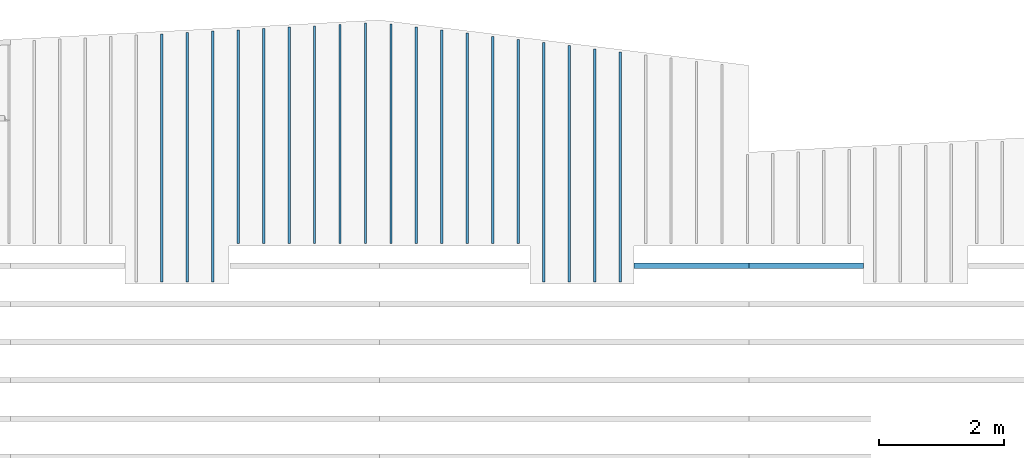
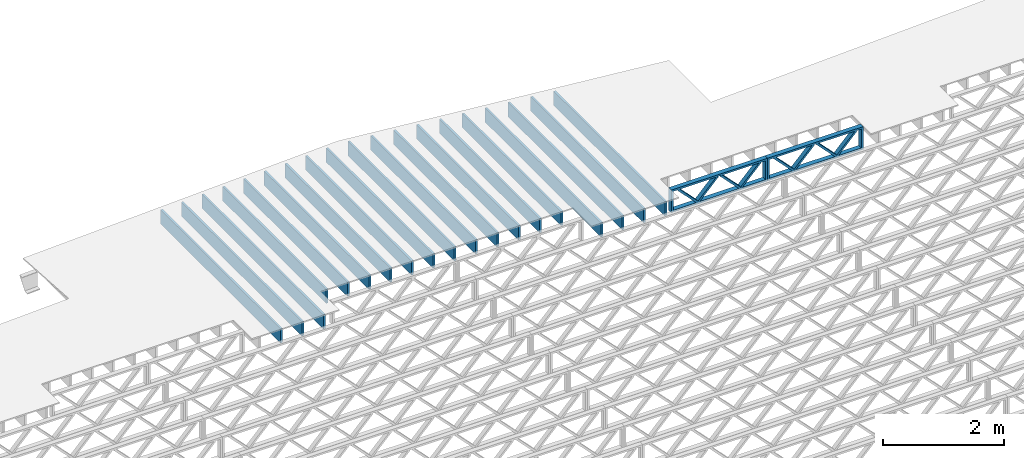
# One storey, part 8 of 12: 21 beams, 3 elements without a shape of their own.
"""IFC4 building model written with IfcOpenShell, lengths in feet."""

from ifc_helpers import new_model, entity, si_unit, converted_unit, derived_unit, direction, frame, frame_2d, origin, origin_2d_with_axis, place, context, subcontext, project, spatial, rectangle, extrude, source, transform, mapped, material, material_profile, profile_set, profile_usage, type_object, type_shapes, element, aggregate, save


model = new_model("IFC4")

# Units and contexts
model_context = context("Model", 3, precision=0.0001, world=origin(), true_north=direction((6.12303176911189e-17, 1.0)))
body_context = subcontext(model_context, "Body", "Model", "MODEL_VIEW")
ifc_project = project(units=[converted_unit("LENGTHUNIT", "FOOT", entity("IfcRatioMeasure", 0.3048), si_unit("LENGTHUNIT", "METRE"), dimensions=[1, 0, 0, 0, 0, 0, 0]), converted_unit("AREAUNIT", "SQUARE FOOT", entity("IfcRatioMeasure", 0.09290304), si_unit("AREAUNIT", "SQUARE_METRE"), dimensions=[2, 0, 0, 0, 0, 0, 0]), converted_unit("VOLUMEUNIT", "CUBIC FOOT", entity("IfcRatioMeasure", 0.028316846592), si_unit("VOLUMEUNIT", "CUBIC_METRE"), dimensions=[3, 0, 0, 0, 0, 0, 0]), converted_unit("PLANEANGLEUNIT", "DEGREE", entity("IfcRatioMeasure", 0.0174532925199433), si_unit("PLANEANGLEUNIT", "RADIAN"), dimensions=[0, 0, 0, 0, 0, 0, 0]), si_unit("MASSUNIT", "GRAM", prefix="KILO"), derived_unit("MASSDENSITYUNIT", [(si_unit("MASSUNIT", "GRAM", prefix="KILO"), 1), (si_unit("LENGTHUNIT", "METRE"), -3)]), derived_unit("MOMENTOFINERTIAUNIT", [(si_unit("LENGTHUNIT", "METRE"), 4)]), si_unit("TIMEUNIT", "SECOND"), si_unit("FREQUENCYUNIT", "HERTZ"), si_unit("THERMODYNAMICTEMPERATUREUNIT", "DEGREE_CELSIUS"), derived_unit("THERMALTRANSMITTANCEUNIT", [(si_unit("MASSUNIT", "GRAM", prefix="KILO"), 1), (si_unit("THERMODYNAMICTEMPERATUREUNIT", "KELVIN"), -1), (si_unit("TIMEUNIT", "SECOND"), -3)]), derived_unit("VOLUMETRICFLOWRATEUNIT", [(si_unit("LENGTHUNIT", "METRE"), 3), (si_unit("TIMEUNIT", "SECOND"), -1)]), si_unit("ELECTRICCURRENTUNIT", "AMPERE"), si_unit("ELECTRICVOLTAGEUNIT", "VOLT"), si_unit("POWERUNIT", "WATT"), si_unit("FORCEUNIT", "NEWTON"), si_unit("ILLUMINANCEUNIT", "LUX"), si_unit("LUMINOUSFLUXUNIT", "LUMEN"), si_unit("LUMINOUSINTENSITYUNIT", "CANDELA"), derived_unit("USERDEFINED", [(si_unit("MASSUNIT", "GRAM", prefix="KILO"), -1), (si_unit("LENGTHUNIT", "METRE"), -2), (si_unit("TIMEUNIT", "SECOND"), 3), (si_unit("LUMINOUSFLUXUNIT", "LUMEN"), 1)]), derived_unit("LINEARVELOCITYUNIT", [(si_unit("LENGTHUNIT", "METRE"), 1), (si_unit("TIMEUNIT", "SECOND"), -1)]), si_unit("PRESSUREUNIT", "PASCAL"), derived_unit("USERDEFINED", [(si_unit("LENGTHUNIT", "METRE"), -2), (si_unit("MASSUNIT", "GRAM", prefix="KILO"), 1), (si_unit("TIMEUNIT", "SECOND"), -2)]), derived_unit("LINEARFORCEUNIT", [(si_unit("MASSUNIT", "GRAM", prefix="KILO"), 1), (si_unit("LENGTHUNIT", "METRE"), 1), (si_unit("TIMEUNIT", "SECOND"), -2), (si_unit("LENGTHUNIT", "METRE"), -1)]), derived_unit("PLANARFORCEUNIT", [(si_unit("MASSUNIT", "GRAM", prefix="KILO"), 1), (si_unit("LENGTHUNIT", "METRE"), 1), (si_unit("TIMEUNIT", "SECOND"), -2), (si_unit("LENGTHUNIT", "METRE"), -2)])], contexts=[model_context])

# Site, building, storey
site_placement = place(None, origin())
site = spatial("IfcSite", under=ifc_project, at=site_placement, CompositionType="ELEMENT")
building_placement = place(site_placement, origin())
building = spatial("IfcBuilding", under=site, at=building_placement, CompositionType="ELEMENT")
storey_placement = place(building_placement, frame((0.0, 0.0, 21.46875)))
storey = spatial("IfcBuildingStorey", under=building, at=storey_placement, Name="3RD FLOOR", CompositionType="ELEMENT", Elevation=21.46875)

# Assembly, beam
assembly_1_placement = place(storey_placement, origin())
assembly_1 = element("IfcElementAssembly", 1, at=assembly_1_placement, inside=storey, Name="Structural Beam System:Structural Framing System", ObjectType="Structural Beam System:Structural Framing System", AssemblyPlace="NOTDEFINED", PredefinedType="BEAM_GRID")
ifc_material_1 = material(Name="WOOD TRUSS", Category="Materials")
ifc_material_profile_1 = material_profile(ifc_material_1, rectangle(XDim=1.73473973950632, YDim=0.125, at=frame_2d((-1.11022302462516e-16, 8.32667268468867e-17), x_axis=(1.0, 0.0))))
ifc_material_profile_2 = material_profile(ifc_material_1, rectangle(XDim=1.73473973950633, YDim=0.125, at=frame_2d((-1.11022302462516e-16, 8.32667268468867e-17), x_axis=(1.0, 0.0))))
ifc_material_profile_3 = material_profile(ifc_material_1, rectangle(XDim=1.73473973950632, YDim=0.125, at=frame_2d((-5.55111512312578e-17, 1.38777878078145e-16), x_axis=(1.0, 0.0))))
ifc_material_profile_4 = material_profile(ifc_material_1, rectangle(XDim=1.73473973950633, YDim=0.125, at=frame_2d((-1.11022302462516e-16, 8.32667268468867e-17), x_axis=(1.0, 0.0))))
ifc_material_profile_5 = material_profile(ifc_material_1, rectangle(XDim=1.73473973950632, YDim=0.125, at=frame_2d((-1.11022302462516e-16, 8.32667268468867e-17), x_axis=(1.0, 0.0))))
ifc_material_profile_6 = material_profile(ifc_material_1, rectangle(XDim=1.73473973950633, YDim=0.125, at=frame_2d((-2.77555756156289e-16, 3.05311331771918e-16), x_axis=(1.0, 0.0))))
ifc_material_profile_7 = material_profile(ifc_material_1, rectangle(XDim=1.73473973950632, YDim=0.124999999999999, at=frame_2d((-3.88578058618805e-16, -2.4980018054066e-16), x_axis=(1.0, 0.0))))
ifc_material_profile_8 = material_profile(ifc_material_1, rectangle(XDim=1.73473973950633, YDim=0.125, at=frame_2d((2.77555756156289e-16, -3.05311331771918e-16), x_axis=(1.0, 0.0))))
ifc_material_profile_9 = material_profile(ifc_material_1, rectangle(XDim=1.73473973950632, YDim=0.124999999999999, at=frame_2d((-1.11022302462516e-16, 8.32667268468867e-17), x_axis=(1.0, 0.0))))
ifc_material_profile_10 = material_profile(ifc_material_1, rectangle(XDim=1.73473973950633, YDim=0.125, at=origin_2d_with_axis()))
ifc_material_profile_11 = material_profile(ifc_material_1, rectangle(XDim=0.124999999999982, YDim=0.291666666666668, at=origin_2d_with_axis()))
ifc_material_profile_12 = material_profile(ifc_material_1, rectangle(XDim=0.124999999999932, YDim=0.291666666666664, at=origin_2d_with_axis()))
ifc_material_profile_13 = material_profile(ifc_material_1, rectangle(XDim=1.25000000000002, YDim=0.29166666666667, at=origin_2d_with_axis()))
ifc_material_profile_14 = material_profile(ifc_material_1, rectangle(XDim=1.25000000000004, YDim=0.291666666666667, at=origin_2d_with_axis()))
ifc_profile_set_1 = profile_set([ifc_material_profile_1, ifc_material_profile_2, ifc_material_profile_3, ifc_material_profile_4, ifc_material_profile_5, ifc_material_profile_6, ifc_material_profile_7, ifc_material_profile_8, ifc_material_profile_9, ifc_material_profile_10, ifc_material_profile_11, ifc_material_profile_12, ifc_material_profile_13, ifc_material_profile_14])
ifc_profile_usage_1 = profile_usage(ifc_profile_set_1, cardinal=8)
beam_type_1 = type_object("IfcBeamType", PredefinedType="BEAM", material=ifc_profile_set_1)
shared_shape_1 = source(origin(), body_context, "Body", "SweptSolid", [
    extrude(rectangle(XDim=1.73473973950632, YDim=0.125, at=frame_2d((0.0, 1.66533453693773e-16), x_axis=(1.0, 0.0))), frame((1.95847612494153, -0.145833333333334, 0.0), z_axis=(0.0, 1.0, 0.0), x_axis=(0.693383046997606, 0.0, 0.720569184836762)), (0.0, 0.0, 1.0), 0.291666666666667),
    extrude(rectangle(XDim=1.73473973950633, YDim=0.125, at=frame_2d((-5.55111512312578e-17, 8.32667268468867e-17), x_axis=(1.0, 0.0))), frame((0.708190251268258, -0.145833333333334, 0.0), z_axis=(0.0, 1.0, 0.0), x_axis=(0.69338304699761, 0.0, -0.720569184836758)), (0.0, 0.0, 1.0), 0.291666666666667),
    extrude(rectangle(XDim=1.73473973950632, YDim=0.125, at=frame_2d((0.0, 1.66533453693773e-16), x_axis=(1.0, 0.0))), frame((-0.708190251267602, -0.145833333333334, 0.0), z_axis=(0.0, 1.0, 0.0), x_axis=(0.693383046997606, 0.0, 0.720569184836762)), (0.0, 0.0, 1.0), 0.291666666666667),
    extrude(rectangle(XDim=1.73473973950633, YDim=0.125, at=frame_2d((-2.22044604925031e-16, 2.22044604925031e-16), x_axis=(1.0, 0.0))), frame((-1.95847612494087, -0.145833333333334, 0.0), z_axis=(0.0, 1.0, 0.0), x_axis=(0.69338304699761, 0.0, -0.720569184836758)), (0.0, 0.0, 1.0), 0.291666666666666),
    extrude(rectangle(XDim=0.124999999999982, YDim=0.291666666666668, at=origin_2d_with_axis()), frame((-2.99999985477115, 0.0, 0.687500000000054), z_axis=(1.0, 0.0, 0.0), x_axis=(0.0, 0.0, -1.0)), (0.0, 0.0, 1.0), 5.99999970954229),
    extrude(rectangle(XDim=0.124999999999932, YDim=0.291666666666664, at=origin_2d_with_axis()), frame((-2.99999985477093, 0.0, -0.687499999999984), z_axis=(1.0, 0.0, 0.0), x_axis=(0.0, 0.0, -1.0)), (0.0, 0.0, 1.0), 5.99999970954208),
    extrude(rectangle(XDim=1.25000000000002, YDim=0.29166666666667, at=origin_2d_with_axis()), frame((2.87499985477113, 0.0, 0.0), z_axis=(1.0, 0.0, 0.0), x_axis=(0.0, 0.0, -1.0)), (0.0, 0.0, 1.0), 0.12500000000002),
    extrude(rectangle(XDim=1.25000000000004, YDim=0.291666666666667, at=origin_2d_with_axis()), frame((-2.99999985477115, 0.0, 0.0), z_axis=(1.0, 0.0, 0.0), x_axis=(0.0, 0.0, -1.0)), (0.0, 0.0, 1.0), 0.125000000000023),
])
type_shapes(beam_type_1, [shared_shape_1])
beam_1_placement = place(assembly_1_placement, frame((-180.738160630791, 957.861934882651, -0.947916666666654), z_axis=(0.0, 0.0, 1.0), x_axis=(-1.0, 0.0, 0.0)))
beam_1 = element("IfcBeam", 2, at=beam_1_placement, type_object=beam_type_1, material=ifc_profile_usage_1, PredefinedType="BEAM", context=body_context, shape_type="MappedRepresentation", body=[
    mapped(shared_shape_1, transform((0.0, 0.0, 0.0), scale=1.0)),
])
aggregate(assembly_1, [beam_1])

assembly_2_placement = place(storey_placement, origin())
assembly_2 = element("IfcElementAssembly", 3, at=assembly_2_placement, inside=storey, Name="Structural Beam System:Structural Framing System", ObjectType="Structural Beam System:Structural Framing System", AssemblyPlace="NOTDEFINED", PredefinedType="BEAM_GRID")
ifc_profile_usage_2 = profile_usage(ifc_profile_set_1, cardinal=8)
beam_type_2 = type_object("IfcBeamType", PredefinedType="BEAM", material=ifc_profile_set_1)
shared_shape_2 = source(origin(), body_context, "Body", "SweptSolid", [
    extrude(rectangle(XDim=1.73473973950632, YDim=0.125, at=frame_2d((0.0, 1.66533453693773e-16), x_axis=(1.0, 0.0))), frame((1.95847610985504, -0.145833333333334, 0.0), z_axis=(0.0, 1.0, 0.0), x_axis=(0.693383046997606, 0.0, 0.720569184836762)), (0.0, 0.0, 1.0), 0.291666666666667),
    extrude(rectangle(XDim=1.73473973950633, YDim=0.125, at=frame_2d((-5.55111512312578e-17, 8.32667268468867e-17), x_axis=(1.0, 0.0))), frame((0.708190236181772, -0.145833333333334, 0.0), z_axis=(0.0, 1.0, 0.0), x_axis=(0.69338304699761, 0.0, -0.720569184836758)), (0.0, 0.0, 1.0), 0.291666666666667),
    extrude(rectangle(XDim=1.73473973950632, YDim=0.125, at=frame_2d((0.0, 1.66533453693773e-16), x_axis=(1.0, 0.0))), frame((-0.708190236181118, -0.145833333333334, 0.0), z_axis=(0.0, 1.0, 0.0), x_axis=(0.693383046997606, 0.0, 0.720569184836762)), (0.0, 0.0, 1.0), 0.291666666666667),
    extrude(rectangle(XDim=1.73473973950633, YDim=0.125, at=frame_2d((-2.22044604925031e-16, 2.22044604925031e-16), x_axis=(1.0, 0.0))), frame((-1.95847610985439, -0.145833333333334, 0.0), z_axis=(0.0, 1.0, 0.0), x_axis=(0.69338304699761, 0.0, -0.720569184836758)), (0.0, 0.0, 1.0), 0.291666666666666),
    extrude(rectangle(XDim=0.124999999999982, YDim=0.291666666666668, at=origin_2d_with_axis()), frame((-2.99999983968466, 0.0, 0.687500000000054), z_axis=(1.0, 0.0, 0.0), x_axis=(0.0, 0.0, -1.0)), (0.0, 0.0, 1.0), 5.99999967936932),
    extrude(rectangle(XDim=0.124999999999932, YDim=0.291666666666664, at=origin_2d_with_axis()), frame((-2.99999983968445, 0.0, -0.687499999999984), z_axis=(1.0, 0.0, 0.0), x_axis=(0.0, 0.0, -1.0)), (0.0, 0.0, 1.0), 5.99999967936911),
    extrude(rectangle(XDim=1.25000000000002, YDim=0.29166666666667, at=origin_2d_with_axis()), frame((2.87499983968464, 0.0, 0.0), z_axis=(1.0, 0.0, 0.0), x_axis=(0.0, 0.0, -1.0)), (0.0, 0.0, 1.0), 0.12500000000002),
    extrude(rectangle(XDim=1.25000000000004, YDim=0.291666666666667, at=origin_2d_with_axis()), frame((-2.99999983968466, 0.0, 0.0), z_axis=(1.0, 0.0, 0.0), x_axis=(0.0, 0.0, -1.0)), (0.0, 0.0, 1.0), 0.125000000000023),
])
type_shapes(beam_type_2, [shared_shape_2])
beam_2_placement = place(assembly_2_placement, frame((-186.738160325248, 957.861934882651, -0.947916666666874)))
beam_2 = element("IfcBeam", 4, at=beam_2_placement, type_object=beam_type_2, material=ifc_profile_usage_2, PredefinedType="BEAM", context=body_context, shape_type="MappedRepresentation", body=[
    mapped(shared_shape_2, transform((0.0, 0.0, 0.0), scale=1.0)),
])
aggregate(assembly_2, [beam_2])

# Assembly, beams
assembly_3_placement = place(storey_placement, origin())
assembly_3 = element("IfcElementAssembly", 5, at=assembly_3_placement, inside=storey, Name="Structural Beam System:Structural Framing System", ObjectType="Structural Beam System:Structural Framing System", AssemblyPlace="NOTDEFINED", PredefinedType="BEAM_GRID")
ifc_material_2 = material(Category="Materials")
ifc_material_profile_15 = material_profile(ifc_material_2, rectangle(XDim=0.9375, YDim=0.125000000000011, at=origin_2d_with_axis()))
ifc_profile_set_2 = profile_set([ifc_material_profile_15])
ifc_profile_usage_3 = profile_usage(ifc_profile_set_2, cardinal=8)
beam_type_3 = type_object("IfcBeamType", PredefinedType="BEAM", material=ifc_profile_set_2)
shared_shape_3 = source(origin(), body_context, "Body", "SweptSolid", [
    extrude(rectangle(XDim=0.9375, YDim=0.125000000000011, at=origin_2d_with_axis()), frame((-6.49165603810872, 0.0, 0.0), z_axis=(1.0, 0.0, 0.0), x_axis=(0.0, 0.0, -1.0)), (0.0, 0.0, 1.0), 12.9833120762174),
])
type_shapes(beam_type_3, [shared_shape_3])
beam_3_placement = place(assembly_3_placement, frame((-214.477622719368, 963.521172258487, -0.729166666666714), z_axis=(0.0, 0.0, 1.0), x_axis=(0.0, 1.0, 0.0)))
beam_3 = element("IfcBeam", 6, at=beam_3_placement, type_object=beam_type_3, material=ifc_profile_usage_3, PredefinedType="BEAM", context=body_context, shape_type="MappedRepresentation", body=[
    mapped(shared_shape_3, transform((0.0, 0.0, 0.0), scale=1.0)),
])
ifc_profile_usage_4 = profile_usage(ifc_profile_set_2, cardinal=8)
beam_type_4 = type_object("IfcBeamType", PredefinedType="BEAM", material=ifc_profile_set_2)
shared_shape_4 = source(origin(), body_context, "Body", "SweptSolid", [
    extrude(rectangle(XDim=0.9375, YDim=0.125000000000011, at=origin_2d_with_axis()), frame((-6.52659455763063, 0.0, 0.0), z_axis=(1.0, 0.0, 0.0), x_axis=(0.0, 0.0, -1.0)), (0.0, 0.0, 1.0), 13.0531891152613),
])
type_shapes(beam_type_4, [shared_shape_4])
beam_4_placement = place(assembly_3_placement, frame((-213.144289386034, 963.556110778009, -0.729166666666714), z_axis=(0.0, 0.0, 1.0), x_axis=(0.0, 1.0, 0.0)))
beam_4 = element("IfcBeam", 7, at=beam_4_placement, type_object=beam_type_4, material=ifc_profile_usage_4, PredefinedType="BEAM", context=body_context, shape_type="MappedRepresentation", body=[
    mapped(shared_shape_4, transform((0.0, 0.0, 0.0), scale=1.0)),
])
ifc_profile_usage_5 = profile_usage(ifc_profile_set_2, cardinal=8)
beam_type_5 = type_object("IfcBeamType", PredefinedType="BEAM", material=ifc_profile_set_2)
shared_shape_5 = source(origin(), body_context, "Body", "SweptSolid", [
    extrude(rectangle(XDim=0.9375, YDim=0.125000000000011, at=origin_2d_with_axis()), frame((-6.5615330771526, 0.0, 0.0), z_axis=(1.0, 0.0, 0.0), x_axis=(0.0, 0.0, -1.0)), (0.0, 0.0, 1.0), 13.1230661543052),
])
type_shapes(beam_type_5, [shared_shape_5])
beam_5_placement = place(assembly_3_placement, frame((-211.810956052701, 963.591049297531, -0.729166666666714), z_axis=(0.0, 0.0, 1.0), x_axis=(0.0, 1.0, 0.0)))
beam_5 = element("IfcBeam", 8, at=beam_5_placement, type_object=beam_type_5, material=ifc_profile_usage_5, PredefinedType="BEAM", context=body_context, shape_type="MappedRepresentation", body=[
    mapped(shared_shape_5, transform((0.0, 0.0, 0.0), scale=1.0)),
])
ifc_profile_usage_6 = profile_usage(ifc_profile_set_2, cardinal=8)
beam_type_6 = type_object("IfcBeamType", PredefinedType="BEAM", material=ifc_profile_set_2)
shared_shape_6 = source(origin(), body_context, "Body", "SweptSolid", [
    extrude(rectangle(XDim=0.9375, YDim=0.125000000000011, at=origin_2d_with_axis()), frame((-5.59693092475834, 0.0, 0.0), z_axis=(1.0, 0.0, 0.0), x_axis=(0.0, 0.0, -1.0)), (0.0, 0.0, 1.0), 11.1938618495167),
])
type_shapes(beam_type_6, [shared_shape_6])
beam_6_placement = place(assembly_3_placement, frame((-210.477622719368, 964.625528488969, -0.729166666666714), z_axis=(0.0, 0.0, 1.0), x_axis=(0.0, 1.0, 0.0)))
beam_6 = element("IfcBeam", 9, at=beam_6_placement, type_object=beam_type_6, material=ifc_profile_usage_6, PredefinedType="BEAM", context=body_context, shape_type="MappedRepresentation", body=[
    mapped(shared_shape_6, transform((0.0, 0.0, 0.0), scale=1.0)),
])
ifc_profile_usage_7 = profile_usage(ifc_profile_set_2, cardinal=8)
beam_type_7 = type_object("IfcBeamType", PredefinedType="BEAM", material=ifc_profile_set_2)
shared_shape_7 = source(origin(), body_context, "Body", "SweptSolid", [
    extrude(rectangle(XDim=0.9375, YDim=0.125000000000011, at=origin_2d_with_axis()), frame((-5.63186927670205, 0.0, 0.0), z_axis=(1.0, 0.0, 0.0), x_axis=(0.0, 0.0, -1.0)), (0.0, 0.0, 1.0), 11.2637385534041),
])
type_shapes(beam_type_7, [shared_shape_7])
beam_7_placement = place(assembly_3_placement, frame((-209.144289386034, 964.660467176069, -0.729166666666714), z_axis=(0.0, 0.0, 1.0), x_axis=(0.0, 1.0, 0.0)))
beam_7 = element("IfcBeam", 10, at=beam_7_placement, type_object=beam_type_7, material=ifc_profile_usage_7, PredefinedType="BEAM", context=body_context, shape_type="MappedRepresentation", body=[
    mapped(shared_shape_7, transform((0.0, 0.0, 0.0), scale=1.0)),
])
ifc_profile_usage_8 = profile_usage(ifc_profile_set_2, cardinal=8)
beam_type_8 = type_object("IfcBeamType", PredefinedType="BEAM", material=ifc_profile_set_2)
shared_shape_8 = source(origin(), body_context, "Body", "SweptSolid", [
    extrude(rectangle(XDim=0.9375, YDim=0.125000000000011, at=origin_2d_with_axis()), frame((-5.66680762864587, 0.0, 0.0), z_axis=(1.0, 0.0, 0.0), x_axis=(0.0, 0.0, -1.0)), (0.0, 0.0, 1.0), 11.3336152572917),
])
type_shapes(beam_type_8, [shared_shape_8])
beam_8_placement = place(assembly_3_placement, frame((-207.810956052701, 964.695405863169, -0.729166666666714), z_axis=(0.0, 0.0, 1.0), x_axis=(0.0, 1.0, 0.0)))
beam_8 = element("IfcBeam", 11, at=beam_8_placement, type_object=beam_type_8, material=ifc_profile_usage_8, PredefinedType="BEAM", context=body_context, shape_type="MappedRepresentation", body=[
    mapped(shared_shape_8, transform((0.0, 0.0, 0.0), scale=1.0)),
])
ifc_profile_usage_9 = profile_usage(ifc_profile_set_2, cardinal=8)
beam_type_9 = type_object("IfcBeamType", PredefinedType="BEAM", material=ifc_profile_set_2)
shared_shape_9 = source(origin(), body_context, "Body", "SweptSolid", [
    extrude(rectangle(XDim=0.9375, YDim=0.125000000000011, at=origin_2d_with_axis()), frame((-5.70174598058964, 0.0, 0.0), z_axis=(1.0, 0.0, 0.0), x_axis=(0.0, 0.0, -1.0)), (0.0, 0.0, 1.0), 11.4034919611793),
])
type_shapes(beam_type_9, [shared_shape_9])
beam_9_placement = place(assembly_3_placement, frame((-206.477622719368, 964.730344550269, -0.729166666666714), z_axis=(0.0, 0.0, 1.0), x_axis=(0.0, 1.0, 0.0)))
beam_9 = element("IfcBeam", 12, at=beam_9_placement, type_object=beam_type_9, material=ifc_profile_usage_9, PredefinedType="BEAM", context=body_context, shape_type="MappedRepresentation", body=[
    mapped(shared_shape_9, transform((0.0, 0.0, 0.0), scale=1.0)),
])
ifc_profile_usage_10 = profile_usage(ifc_profile_set_2, cardinal=8)
beam_type_10 = type_object("IfcBeamType", PredefinedType="BEAM", material=ifc_profile_set_2)
shared_shape_10 = source(origin(), body_context, "Body", "SweptSolid", [
    extrude(rectangle(XDim=0.9375, YDim=0.125000000000011, at=origin_2d_with_axis()), frame((-5.7366843325334, 0.0, 0.0), z_axis=(1.0, 0.0, 0.0), x_axis=(0.0, 0.0, -1.0)), (0.0, 0.0, 1.0), 11.4733686650668),
])
type_shapes(beam_type_10, [shared_shape_10])
beam_10_placement = place(assembly_3_placement, frame((-205.144289386034, 964.765283237369, -0.729166666666714), z_axis=(0.0, 0.0, 1.0), x_axis=(0.0, 1.0, 0.0)))
beam_10 = element("IfcBeam", 13, at=beam_10_placement, type_object=beam_type_10, material=ifc_profile_usage_10, PredefinedType="BEAM", context=body_context, shape_type="MappedRepresentation", body=[
    mapped(shared_shape_10, transform((0.0, 0.0, 0.0), scale=1.0)),
])
ifc_profile_usage_11 = profile_usage(ifc_profile_set_2, cardinal=8)
beam_type_11 = type_object("IfcBeamType", PredefinedType="BEAM", material=ifc_profile_set_2)
shared_shape_11 = source(origin(), body_context, "Body", "SweptSolid", [
    extrude(rectangle(XDim=0.9375, YDim=0.125000000000011, at=origin_2d_with_axis()), frame((-5.77162268447722, 0.0, 0.0), z_axis=(1.0, 0.0, 0.0), x_axis=(0.0, 0.0, -1.0)), (0.0, 0.0, 1.0), 11.5432453689544),
])
type_shapes(beam_type_11, [shared_shape_11])
beam_11_placement = place(assembly_3_placement, frame((-203.810956052701, 964.80022192447, -0.729166666666714), z_axis=(0.0, 0.0, 1.0), x_axis=(0.0, 1.0, 0.0)))
beam_11 = element("IfcBeam", 14, at=beam_11_placement, type_object=beam_type_11, material=ifc_profile_usage_11, PredefinedType="BEAM", context=body_context, shape_type="MappedRepresentation", body=[
    mapped(shared_shape_11, transform((0.0, 0.0, 0.0), scale=1.0)),
])
ifc_profile_usage_12 = profile_usage(ifc_profile_set_2, cardinal=8)
beam_type_12 = type_object("IfcBeamType", PredefinedType="BEAM", material=ifc_profile_set_2)
shared_shape_12 = source(origin(), body_context, "Body", "SweptSolid", [
    extrude(rectangle(XDim=0.9375, YDim=0.125000000000011, at=origin_2d_with_axis()), frame((-5.75414289160091, 0.0, 0.0), z_axis=(1.0, 0.0, 0.0), x_axis=(0.0, 0.0, -1.0)), (0.0, 0.0, 1.0), 11.5082857832018),
])
type_shapes(beam_type_12, [shared_shape_12])
beam_12_placement = place(assembly_3_placement, frame((-202.477622729298, 964.782742543594, -0.729166666666714), z_axis=(0.0, 0.0, 1.0), x_axis=(0.0, 1.0, 0.0)))
beam_12 = element("IfcBeam", 15, at=beam_12_placement, type_object=beam_type_12, material=ifc_profile_usage_12, PredefinedType="BEAM", context=body_context, shape_type="MappedRepresentation", body=[
    mapped(shared_shape_12, transform((0.0, 0.0, 0.0), scale=1.0)),
])
ifc_profile_usage_13 = profile_usage(ifc_profile_set_2, cardinal=8)
beam_type_13 = type_object("IfcBeamType", PredefinedType="BEAM", material=ifc_profile_set_2)
shared_shape_13 = source(origin(), body_context, "Body", "SweptSolid", [
    extrude(rectangle(XDim=0.9375, YDim=0.125000000000011, at=origin_2d_with_axis()), frame((-5.67228635016443, 0.0, 0.0), z_axis=(1.0, 0.0, 0.0), x_axis=(0.0, 0.0, -1.0)), (0.0, 0.0, 1.0), 11.3445727003289),
])
type_shapes(beam_type_13, [shared_shape_13])
beam_13_placement = place(assembly_3_placement, frame((-201.144289395965, 964.700886337237, -0.729166666666714), z_axis=(0.0, 0.0, 1.0), x_axis=(0.0, 1.0, 0.0)))
beam_13 = element("IfcBeam", 16, at=beam_13_placement, type_object=beam_type_13, material=ifc_profile_usage_13, PredefinedType="BEAM", context=body_context, shape_type="MappedRepresentation", body=[
    mapped(shared_shape_13, transform((0.0, 0.0, 0.0), scale=1.0)),
])
ifc_profile_usage_14 = profile_usage(ifc_profile_set_2, cardinal=8)
beam_type_14 = type_object("IfcBeamType", PredefinedType="BEAM", material=ifc_profile_set_2)
shared_shape_14 = source(origin(), body_context, "Body", "SweptSolid", [
    extrude(rectangle(XDim=0.9375, YDim=0.125000000000011, at=origin_2d_with_axis()), frame((-5.59042980872806, 0.0, 0.0), z_axis=(1.0, 0.0, 0.0), x_axis=(0.0, 0.0, -1.0)), (0.0, 0.0, 1.0), 11.1808596174561),
])
type_shapes(beam_type_14, [shared_shape_14])
beam_14_placement = place(assembly_3_placement, frame((-199.810956062631, 964.619030130879, -0.729166666666714), z_axis=(0.0, 0.0, 1.0), x_axis=(0.0, 1.0, 0.0)))
beam_14 = element("IfcBeam", 17, at=beam_14_placement, type_object=beam_type_14, material=ifc_profile_usage_14, PredefinedType="BEAM", context=body_context, shape_type="MappedRepresentation", body=[
    mapped(shared_shape_14, transform((0.0, 0.0, 0.0), scale=1.0)),
])
ifc_profile_usage_15 = profile_usage(ifc_profile_set_2, cardinal=8)
beam_type_15 = type_object("IfcBeamType", PredefinedType="BEAM", material=ifc_profile_set_2)
shared_shape_15 = source(origin(), body_context, "Body", "SweptSolid", [
    extrude(rectangle(XDim=0.9375, YDim=0.125000000000011, at=origin_2d_with_axis()), frame((-5.50857326729164, 0.0, 0.0), z_axis=(1.0, 0.0, 0.0), x_axis=(0.0, 0.0, -1.0)), (0.0, 0.0, 1.0), 11.0171465345833),
])
type_shapes(beam_type_15, [shared_shape_15])
beam_15_placement = place(assembly_3_placement, frame((-198.477622729298, 964.537173924522, -0.729166666666714), z_axis=(0.0, 0.0, 1.0), x_axis=(0.0, 1.0, 0.0)))
beam_15 = element("IfcBeam", 18, at=beam_15_placement, type_object=beam_type_15, material=ifc_profile_usage_15, PredefinedType="BEAM", context=body_context, shape_type="MappedRepresentation", body=[
    mapped(shared_shape_15, transform((0.0, 0.0, 0.0), scale=1.0)),
])
ifc_profile_usage_16 = profile_usage(ifc_profile_set_2, cardinal=8)
beam_type_16 = type_object("IfcBeamType", PredefinedType="BEAM", material=ifc_profile_set_2)
shared_shape_16 = source(origin(), body_context, "Body", "SweptSolid", [
    extrude(rectangle(XDim=0.9375, YDim=0.125000000000011, at=origin_2d_with_axis()), frame((-5.42671672585521, 0.0, 0.0), z_axis=(1.0, 0.0, 0.0), x_axis=(0.0, 0.0, -1.0)), (0.0, 0.0, 1.0), 10.8534334517104),
])
type_shapes(beam_type_16, [shared_shape_16])
beam_16_placement = place(assembly_3_placement, frame((-197.144289395965, 964.455317718165, -0.729166666666714), z_axis=(0.0, 0.0, 1.0), x_axis=(0.0, 1.0, 0.0)))
beam_16 = element("IfcBeam", 19, at=beam_16_placement, type_object=beam_type_16, material=ifc_profile_usage_16, PredefinedType="BEAM", context=body_context, shape_type="MappedRepresentation", body=[
    mapped(shared_shape_16, transform((0.0, 0.0, 0.0), scale=1.0)),
])
ifc_profile_usage_17 = profile_usage(ifc_profile_set_2, cardinal=8)
beam_type_17 = type_object("IfcBeamType", PredefinedType="BEAM", material=ifc_profile_set_2)
shared_shape_17 = source(origin(), body_context, "Body", "SweptSolid", [
    extrude(rectangle(XDim=0.9375, YDim=0.125000000000011, at=origin_2d_with_axis()), frame((-5.34486018441879, 0.0, 0.0), z_axis=(1.0, 0.0, 0.0), x_axis=(0.0, 0.0, -1.0)), (0.0, 0.0, 1.0), 10.6897203688376),
])
type_shapes(beam_type_17, [shared_shape_17])
beam_17_placement = place(assembly_3_placement, frame((-195.810956062631, 964.373461511808, -0.729166666666714), z_axis=(0.0, 0.0, 1.0), x_axis=(0.0, 1.0, 0.0)))
beam_17 = element("IfcBeam", 20, at=beam_17_placement, type_object=beam_type_17, material=ifc_profile_usage_17, PredefinedType="BEAM", context=body_context, shape_type="MappedRepresentation", body=[
    mapped(shared_shape_17, transform((0.0, 0.0, 0.0), scale=1.0)),
])
ifc_profile_usage_18 = profile_usage(ifc_profile_set_2, cardinal=8)
beam_type_18 = type_object("IfcBeamType", PredefinedType="BEAM", material=ifc_profile_set_2)
shared_shape_18 = source(origin(), body_context, "Body", "SweptSolid", [
    extrude(rectangle(XDim=0.9375, YDim=0.125000000000011, at=origin_2d_with_axis()), frame((-6.26300536368484, 0.0, 0.0), z_axis=(1.0, 0.0, 0.0), x_axis=(0.0, 0.0, -1.0)), (0.0, 0.0, 1.0), 12.5260107273697),
])
type_shapes(beam_type_18, [shared_shape_18])
beam_18_placement = place(assembly_3_placement, frame((-194.477622729298, 963.291603584714, -0.729166666666714), z_axis=(0.0, 0.0, 1.0), x_axis=(0.0, 1.0, 0.0)))
beam_18 = element("IfcBeam", 21, at=beam_18_placement, type_object=beam_type_18, material=ifc_profile_usage_18, PredefinedType="BEAM", context=body_context, shape_type="MappedRepresentation", body=[
    mapped(shared_shape_18, transform((0.0, 0.0, 0.0), scale=1.0)),
])
ifc_profile_usage_19 = profile_usage(ifc_profile_set_2, cardinal=8)
beam_type_19 = type_object("IfcBeamType", PredefinedType="BEAM", material=ifc_profile_set_2)
shared_shape_19 = source(origin(), body_context, "Body", "SweptSolid", [
    extrude(rectangle(XDim=0.9375, YDim=0.125000000000011, at=origin_2d_with_axis()), frame((-6.1811489897496, 0.0, 0.0), z_axis=(1.0, 0.0, 0.0), x_axis=(0.0, 0.0, -1.0)), (0.0, 0.0, 1.0), 12.3622979794992),
])
type_shapes(beam_type_19, [shared_shape_19])
beam_19_placement = place(assembly_3_placement, frame((-193.144289395965, 963.209747210779, -0.729166666666714), z_axis=(0.0, 0.0, 1.0), x_axis=(0.0, 1.0, 0.0)))
beam_19 = element("IfcBeam", 22, at=beam_19_placement, type_object=beam_type_19, material=ifc_profile_usage_19, PredefinedType="BEAM", context=body_context, shape_type="MappedRepresentation", body=[
    mapped(shared_shape_19, transform((0.0, 0.0, 0.0), scale=1.0)),
])
ifc_profile_usage_20 = profile_usage(ifc_profile_set_2, cardinal=8)
beam_type_20 = type_object("IfcBeamType", PredefinedType="BEAM", material=ifc_profile_set_2)
shared_shape_20 = source(origin(), body_context, "Body", "SweptSolid", [
    extrude(rectangle(XDim=0.9375, YDim=0.125000000000011, at=origin_2d_with_axis()), frame((-6.09929261581436, 0.0, 0.0), z_axis=(1.0, 0.0, 0.0), x_axis=(0.0, 0.0, -1.0)), (0.0, 0.0, 1.0), 12.1985852316287),
])
type_shapes(beam_type_20, [shared_shape_20])
beam_20_placement = place(assembly_3_placement, frame((-191.810956062631, 963.127890836844, -0.729166666666714), z_axis=(0.0, 0.0, 1.0), x_axis=(0.0, 1.0, 0.0)))
beam_20 = element("IfcBeam", 23, at=beam_20_placement, type_object=beam_type_20, material=ifc_profile_usage_20, PredefinedType="BEAM", context=body_context, shape_type="MappedRepresentation", body=[
    mapped(shared_shape_20, transform((0.0, 0.0, 0.0), scale=1.0)),
])
ifc_profile_usage_21 = profile_usage(ifc_profile_set_2, cardinal=8)
beam_type_21 = type_object("IfcBeamType", PredefinedType="BEAM", material=ifc_profile_set_2)
shared_shape_21 = source(origin(), body_context, "Body", "SweptSolid", [
    extrude(rectangle(XDim=0.9375, YDim=0.125000000000011, at=origin_2d_with_axis()), frame((-6.01743624187907, 0.0, 0.0), z_axis=(1.0, 0.0, 0.0), x_axis=(0.0, 0.0, -1.0)), (0.0, 0.0, 1.0), 12.0348724837581),
])
type_shapes(beam_type_21, [shared_shape_21])
beam_21_placement = place(assembly_3_placement, frame((-190.477622729298, 963.046034462908, -0.729166666666714), z_axis=(0.0, 0.0, 1.0), x_axis=(0.0, 1.0, 0.0)))
beam_21 = element("IfcBeam", 24, at=beam_21_placement, type_object=beam_type_21, material=ifc_profile_usage_21, PredefinedType="BEAM", context=body_context, shape_type="MappedRepresentation", body=[
    mapped(shared_shape_21, transform((0.0, 0.0, 0.0), scale=1.0)),
])
aggregate(assembly_3, [beam_3, beam_4, beam_5, beam_6, beam_7, beam_8, beam_9, beam_10, beam_11, beam_12, beam_13, beam_14, beam_15, beam_16, beam_17, beam_18, beam_19, beam_20, beam_21])

save(model, "model.ifc")
